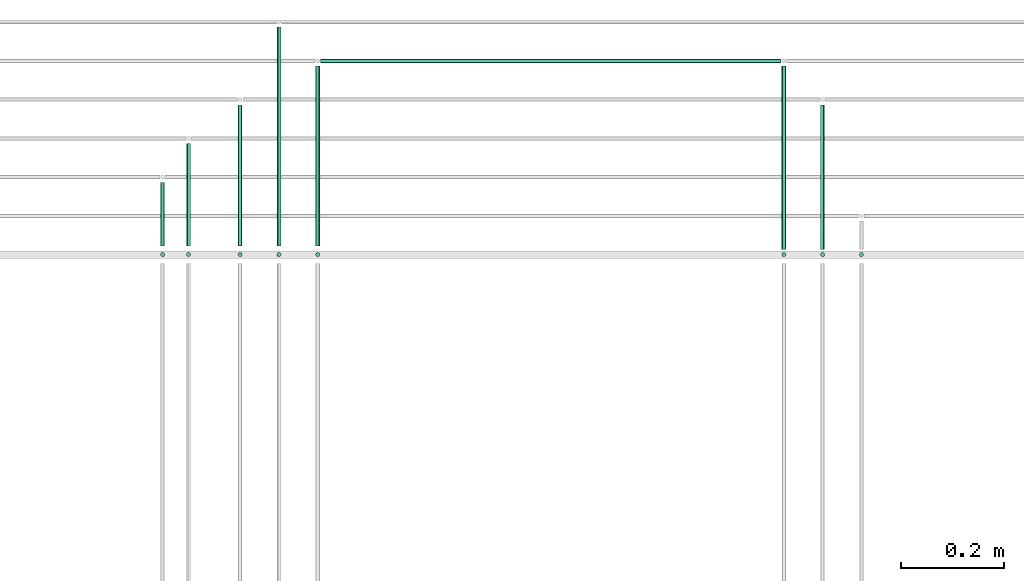
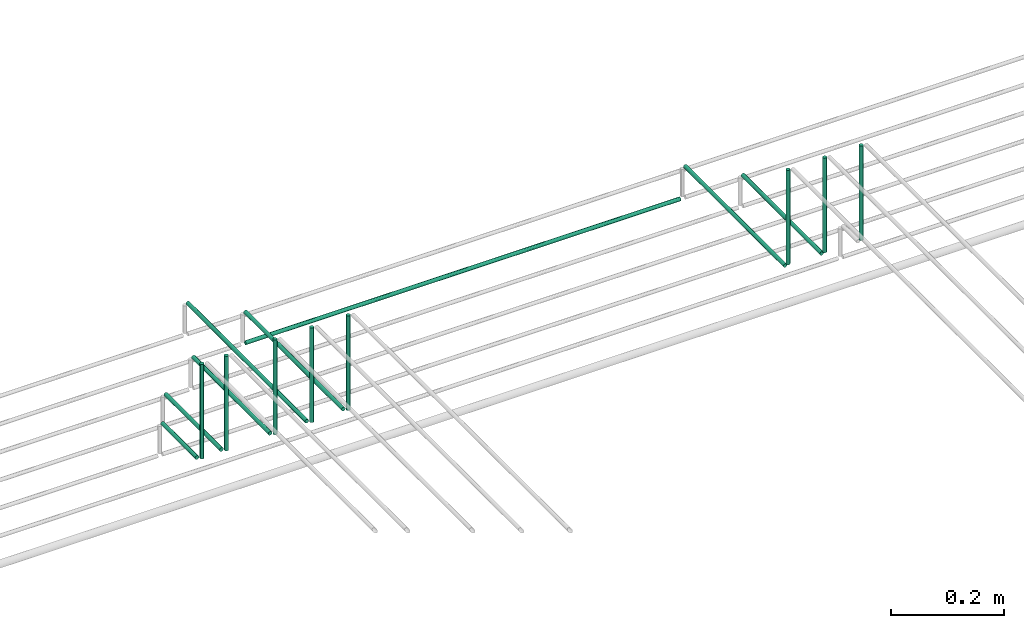
# One storey, part 64 of 89: 16 flow segments.
"""IFC2X3 building model written with IfcOpenShell, lengths in millimetres."""

import ifcopenshell
import ifcopenshell.guid

model = None  # the IFC model being written
_history = None  # IfcOwnerHistory: only IFC2X3 demands one
_inside = {}  # id of a spatial element -> (the spatial element, [elements in it])
_under = {}  # id of a project, library or spatial element -> (it, [spatial elements below it])
_declared = {}  # id of a project -> (the project, [libraries it declares])
_typed = {}  # id of a type object -> (the type object, [elements of that type])
_made_of = {}  # id of a material, layer set ... -> (it, [elements and type objects made of it])


def new_model(schema):
    """Start an empty IFC model of exactly this schema.

    Asked for "IFC4X3", IfcOpenShell would pick the latest addendum, in which some entities
    have other attributes; the version numbers below select the first issue.
    IFC2X3 requires an IfcOwnerHistory on every rooted entity: one is made here for all.
    """
    global model, _history
    if schema == "IFC4X3":
        model = ifcopenshell.file(schema_version=(4, 3, 0, 0))
    else:
        model = ifcopenshell.file(schema=schema)
    _inside.clear()
    _under.clear()
    _declared.clear()
    _typed.clear()
    _made_of.clear()
    _history = None
    if model.schema == "IFC2X3":
        org = make("IfcOrganization", Name="unknown")
        user = make(
            "IfcPersonAndOrganization",
            ThePerson=make("IfcPerson", FamilyName="unknown"),
            TheOrganization=org,
        )
        app = make(
            "IfcApplication",
            ApplicationDeveloper=org,
            Version="unknown",
            ApplicationFullName="unknown",
            ApplicationIdentifier="unknown",
        )
        _history = make(
            "IfcOwnerHistory",
            OwningUser=user,
            OwningApplication=app,
            ChangeAction="ADDED",
            CreationDate=0,
        )
    return model


def make(cls, **values):
    """One entity of the class cls with the attributes given. An attribute that is None is left unset."""
    return model.create_entity(
        cls, **{name: value for name, value in values.items() if value is not None}
    )


def entity(cls, *values):
    """Any entity or typed value of the class cls, its attributes in the order of the schema. None: left unset."""
    e = model.create_entity(cls)
    for i, value in enumerate(values):
        if value is not None:
            e[i] = value
    return e


def rooted(cls, **values):
    """An entity with a GlobalId (a new one), such as an element, a storey or a relation."""
    return make(cls, GlobalId=ifcopenshell.guid.new(), OwnerHistory=_history, **values)


def si_unit(unit_type, name, prefix=None):
    """IfcSIUnit, for example si_unit("LENGTHUNIT", "METRE", prefix="MILLI")."""
    return make("IfcSIUnit", UnitType=unit_type, Prefix=prefix, Name=name)


def converted_unit(unit_type, name, factor, base, dimensions=None, offset=None):
    """IfcConversionBasedUnit, such as the inch: factor (a typed value) times the base unit."""
    return make(
        "IfcConversionBasedUnit"
        if offset is None
        else "IfcConversionBasedUnitWithOffset",
        ConversionOffset=offset,
        Dimensions=None
        if dimensions is None
        else entity("IfcDimensionalExponents", *dimensions),
        UnitType=unit_type,
        Name=name,
        ConversionFactor=make(
            "IfcMeasureWithUnit", ValueComponent=factor, UnitComponent=base
        ),
    )


def derived_unit(unit_type, elements):
    """IfcDerivedUnit: a product of units, each with its exponent."""
    return make(
        "IfcDerivedUnit",
        Elements=[
            make("IfcDerivedUnitElement", Unit=unit, Exponent=power)
            for unit, power in elements
        ],
        UnitType=unit_type,
    )


def assignment(units):
    """IfcUnitAssignment: the units of a project."""
    return None if units is None else make("IfcUnitAssignment", Units=units)


def point(xyz):
    """IfcCartesianPoint."""
    return None if xyz is None else make("IfcCartesianPoint", Coordinates=xyz)


def direction(xyz):
    """IfcDirection."""
    return None if xyz is None else make("IfcDirection", DirectionRatios=xyz)


def frame(location, z_axis=None, x_axis=None):
    """IfcAxis2Placement3D, a coordinate frame: its origin and axes. An axis left out is left unset."""
    return make(
        "IfcAxis2Placement3D",
        Location=point(location),
        Axis=direction(z_axis),
        RefDirection=direction(x_axis),
    )


def frame_2d(location, x_axis=None):
    """IfcAxis2Placement2D, a coordinate frame in the plane: its origin and x axis."""
    return make(
        "IfcAxis2Placement2D", Location=point(location), RefDirection=direction(x_axis)
    )


def origin():
    """The frame at (0, 0, 0) with its axes left unset."""
    return frame((0.0, 0.0, 0.0))


def origin_2d_with_axis():
    """The frame at (0, 0) in the plane with the x axis (1, 0) written out."""
    return frame_2d((0.0, 0.0), x_axis=(1.0, 0.0))


def place(relative_to, where):
    """IfcLocalPlacement: puts the frame where relative to a parent placement (None: the world)."""
    return make(
        "IfcLocalPlacement", PlacementRelTo=relative_to, RelativePlacement=where
    )


def context(
    kind, dimensions, precision=None, world=None, true_north=None, identifier=None
):
    """IfcGeometricRepresentationContext, for example the 3D "Model" context."""
    return make(
        "IfcGeometricRepresentationContext",
        ContextIdentifier=identifier,
        ContextType=kind,
        CoordinateSpaceDimension=dimensions,
        Precision=precision,
        WorldCoordinateSystem=world,
        TrueNorth=true_north,
    )


def subcontext(parent, identifier, kind, view, scale=None):
    """IfcGeometricRepresentationSubContext, for example "Body" below "Model"."""
    return make(
        "IfcGeometricRepresentationSubContext",
        ContextIdentifier=identifier,
        ContextType=kind,
        ParentContext=parent,
        TargetScale=scale,
        TargetView=view,
    )


def project(units=None, contexts=None):
    """IfcProject with its units and contexts."""
    return rooted(
        "IfcProject",
        Name="project",
        RepresentationContexts=contexts,
        UnitsInContext=assignment(units),
    )


def spatial(cls, under=None, at=None, **own):
    """A site, building, storey or space (cls), placed at a placement, below another one or the project."""
    s = rooted(cls, ObjectPlacement=at, **own)
    if under is not None:
        _under.setdefault(under.id(), (under, []))[1].append(s)
    return s


def profile(cls, at=None, kind="AREA", **sizes):
    """A parametric profile (cls). Its sizes go by their IFC names, for example OverallWidth=200.0."""
    return make(cls, ProfileType=kind, Position=at, **sizes)


def circle(**sizes):
    """IfcCircleProfileDef."""
    return profile("IfcCircleProfileDef", **sizes)


def extrude(swept, where, along, depth):
    """IfcExtrudedAreaSolid: the profile swept, set in the frame where, extruded along a direction by depth."""
    return make(
        "IfcExtrudedAreaSolid",
        SweptArea=swept,
        Position=where,
        ExtrudedDirection=direction(along),
        Depth=depth,
    )


def shape(context_of_items, identifier, shape_type, items):
    """IfcShapeRepresentation: the items that make up one representation, for example the "Body"."""
    return make(
        "IfcShapeRepresentation",
        ContextOfItems=context_of_items,
        RepresentationIdentifier=identifier,
        RepresentationType=shape_type,
        Items=items,
    )


def made_of(thing, what):
    """Note that an element or type object is made of a material, layer set ...; save() writes the relation."""
    if what is not None:
        _made_of.setdefault(what.id(), (what, []))[1].append(thing)
    return thing


def type_object(cls, material=None, **own):
    """A type object (cls), such as IfcWallType, which elements share."""
    return made_of(rooted(cls, **own), material)


def element(
    cls,
    number,
    at=None,
    inside=None,
    cuts=None,
    type_object=None,
    material=None,
    context=None,
    identifier="Body",
    shape_type=None,
    held_by="IfcProductDefinitionShape",
    body=None,
    shapes=None,
    **own,
):
    """One element of the class cls, such as IfcWall. Its Tag is "e" and its number.

    at: its placement. inside: the storey or other place that contains it. cuts: it is an
    opening in that element (IfcRelVoidsElement). A single representation is given by context,
    identifier, shape_type and body (its items); several are given by shapes. held_by: the class
    of the entity that holds the representations. save() writes the other relations.
    """
    e = rooted(cls, Tag="e%d" % number, ObjectPlacement=at, **own)
    if body is not None:
        shapes = [shape(context, identifier, shape_type, body)]
    if shapes is not None:
        e.Representation = make(held_by, Representations=shapes)
    if inside is not None:
        _inside.setdefault(inside.id(), (inside, []))[1].append(e)
    if cuts is not None:
        rooted(
            "IfcRelVoidsElement", RelatingBuildingElement=cuts, RelatedOpeningElement=e
        )
    if type_object is not None:
        _typed.setdefault(type_object.id(), (type_object, []))[1].append(e)
    return made_of(e, material)


def aggregate(whole, parts):
    """IfcRelAggregates: a whole, such as a stair, and the parts it consists of."""
    return rooted("IfcRelAggregates", RelatingObject=whole, RelatedObjects=parts)


def save(model, path):
    """Write the relations noted so far, then the file.

    IfcRelAggregates (storeys below a building ...), IfcRelContainedInSpatialStructure (elements
    in a storey), IfcRelDefinesByType, IfcRelAssociatesMaterial and IfcRelDeclares: one each for
    every whole, place, type object, material and project.
    """
    for whole, parts in _under.values():
        aggregate(whole, parts)
    for where, things in _inside.values():
        rooted(
            "IfcRelContainedInSpatialStructure",
            RelatedElements=things,
            RelatingStructure=where,
        )
    for kind, things in _typed.values():
        rooted("IfcRelDefinesByType", RelatedObjects=things, RelatingType=kind)
    for what, things in _made_of.values():
        rooted("IfcRelAssociatesMaterial", RelatedObjects=things, RelatingMaterial=what)
    for by, libraries in _declared.values():
        rooted("IfcRelDeclares", RelatingContext=by, RelatedDefinitions=libraries)
    model.write(path)


model = new_model("IFC2X3")

# Units and contexts
model_context = context("Model", 3, precision=0.01, world=origin(), true_north=direction((6.12303176911189e-17, 1.0)))
body_context = subcontext(model_context, "Body", "Model", "MODEL_VIEW")
ifc_project = project(units=[si_unit("LENGTHUNIT", "METRE", prefix="MILLI"), si_unit("AREAUNIT", "SQUARE_METRE"), si_unit("VOLUMEUNIT", "CUBIC_METRE"), converted_unit("PLANEANGLEUNIT", "DEGREE", entity("IfcRatioMeasure", 0.0174532925199433), si_unit("PLANEANGLEUNIT", "RADIAN"), dimensions=[0, 0, 0, 0, 0, 0, 0]), si_unit("MASSUNIT", "GRAM", prefix="KILO"), derived_unit("MASSDENSITYUNIT", [(si_unit("MASSUNIT", "GRAM", prefix="KILO"), 1), (si_unit("LENGTHUNIT", "METRE"), -3)]), derived_unit("MOMENTOFINERTIAUNIT", [(si_unit("LENGTHUNIT", "METRE"), 4)]), si_unit("TIMEUNIT", "SECOND"), si_unit("FREQUENCYUNIT", "HERTZ"), si_unit("THERMODYNAMICTEMPERATUREUNIT", "DEGREE_CELSIUS"), derived_unit("THERMALTRANSMITTANCEUNIT", [(si_unit("MASSUNIT", "GRAM", prefix="KILO"), 1), (si_unit("THERMODYNAMICTEMPERATUREUNIT", "KELVIN"), -1), (si_unit("TIMEUNIT", "SECOND"), -3)]), derived_unit("VOLUMETRICFLOWRATEUNIT", [(si_unit("LENGTHUNIT", "METRE"), 3), (si_unit("TIMEUNIT", "SECOND"), -1)]), derived_unit("MASSFLOWRATEUNIT", [(si_unit("MASSUNIT", "GRAM", prefix="KILO"), 1), (si_unit("TIMEUNIT", "SECOND"), -1)]), derived_unit("ROTATIONALFREQUENCYUNIT", [(si_unit("TIMEUNIT", "SECOND"), -1)]), si_unit("ELECTRICCURRENTUNIT", "AMPERE"), si_unit("ELECTRICVOLTAGEUNIT", "VOLT"), si_unit("POWERUNIT", "WATT"), si_unit("FORCEUNIT", "NEWTON", prefix="KILO"), si_unit("ILLUMINANCEUNIT", "LUX"), si_unit("LUMINOUSFLUXUNIT", "LUMEN"), si_unit("LUMINOUSINTENSITYUNIT", "CANDELA"), derived_unit("USERDEFINED", [(si_unit("MASSUNIT", "GRAM", prefix="KILO"), -1), (si_unit("LENGTHUNIT", "METRE"), -2), (si_unit("TIMEUNIT", "SECOND"), 3), (si_unit("LUMINOUSFLUXUNIT", "LUMEN"), 1)]), derived_unit("LINEARVELOCITYUNIT", [(si_unit("LENGTHUNIT", "METRE"), 1), (si_unit("TIMEUNIT", "SECOND"), -1)]), si_unit("PRESSUREUNIT", "PASCAL"), derived_unit("USERDEFINED", [(si_unit("LENGTHUNIT", "METRE"), -2), (si_unit("MASSUNIT", "GRAM", prefix="KILO"), 1), (si_unit("TIMEUNIT", "SECOND"), -2)]), derived_unit("LINEARFORCEUNIT", [(si_unit("MASSUNIT", "GRAM", prefix="KILO"), 1), (si_unit("LENGTHUNIT", "METRE"), 1), (si_unit("TIMEUNIT", "SECOND"), -2), (si_unit("LENGTHUNIT", "METRE"), -1)]), derived_unit("PLANARFORCEUNIT", [(si_unit("MASSUNIT", "GRAM", prefix="KILO"), 1), (si_unit("LENGTHUNIT", "METRE"), 1), (si_unit("TIMEUNIT", "SECOND"), -2), (si_unit("LENGTHUNIT", "METRE"), -2)])], contexts=[model_context])

# Site, building, storey
site_placement = place(None, frame((0.0, -0.00077364408347762, 0.0)))
site = spatial("IfcSite", under=ifc_project, at=site_placement, CompositionType="ELEMENT")
building_placement = place(site_placement, origin())
building = spatial("IfcBuilding", under=site, at=building_placement, CompositionType="ELEMENT")
storey_placement = place(building_placement, frame((0.0, 0.0, 24000.0)))
storey = spatial("IfcBuildingStorey", under=building, at=storey_placement, CompositionType="ELEMENT", Elevation=24000.0)

# Flow segments
pipe_segment_type = type_object("IfcPipeSegmentType", PredefinedType="NOTDEFINED")
flow_segment_1_placement = place(storey_placement, frame((58948.2213692066, 18644.5582806598, 2859.99965095085)))
element("IfcFlowSegment", 1, at=flow_segment_1_placement, inside=storey, type_object=pipe_segment_type, context=body_context, shape_type="SweptSolid", body=[
    extrude(circle(Radius=4.0, at=origin_2d_with_axis()), frame((5.5952722206509, 5.59527223591499, 0.000349592837017099), z_axis=(8.73982106718787e-05, 0.0, 0.999999996180776), x_axis=(0.999999996180776, 0.0, -8.73982106718787e-05)), (0.0, 0.0, 1.0), 205.000000850331),
])
flow_segment_2_placement = place(storey_placement, frame((58948.2218546044, 18667.1535528393, 2844.40472924287)))
element("IfcFlowSegment", 2, at=flow_segment_2_placement, inside=storey, type_object=pipe_segment_type, context=body_context, shape_type="SweptSolid", body=[
    extrude(circle(Radius=4.0, at=origin_2d_with_axis()), frame((5.59527223591499, 0.0, 5.59527223591499), z_axis=(0.0, 1.0, 0.0), x_axis=(-1.0, 0.0, 0.0)), (0.0, 0.0, 1.0), 122.846447160764),
])
flow_segment_3_placement = place(storey_placement, frame((58998.2213692066, 18644.5582806598, 2859.99965095085)))
element("IfcFlowSegment", 3, at=flow_segment_3_placement, inside=storey, type_object=pipe_segment_type, context=body_context, shape_type="SweptSolid", body=[
    extrude(circle(Radius=4.0, at=origin_2d_with_axis()), frame((5.59527222064223, 5.59527223591499, 0.000349592837017099), z_axis=(8.73982106718787e-05, 0.0, 0.999999996180776), x_axis=(0.999999996180776, 0.0, -8.73982106718787e-05)), (0.0, 0.0, 1.0), 205.000000850331),
])
for number, where in (
    (4, (59098.2213692066, 18644.5582806598, 2859.99965095085)),
    (5, (59173.2213692066, 18644.5582806598, 2859.99965095085)),
    (6, (59248.2213692066, 18644.5582806598, 2859.99965095085)),
):
    element("IfcFlowSegment", number, at=place(storey_placement, frame(where)), inside=storey, type_object=pipe_segment_type, context=body_context, shape_type="SweptSolid", body=[
        extrude(circle(Radius=4.0, at=origin_2d_with_axis()), frame((5.5952722206509, 5.59527223591499, 0.000349592837017099), z_axis=(8.73982106718787e-05, 0.0, 0.999999996180776), x_axis=(0.999999996180776, 0.0, -8.73982106718787e-05)), (0.0, 0.0, 1.0), 205.000000850331),
    ])
flow_segment_4_placement = place(storey_placement, frame((58998.2218546044, 18667.1535528393, 2844.40472986988)))
element("IfcFlowSegment", 7, at=flow_segment_4_placement, inside=storey, type_object=pipe_segment_type, context=body_context, shape_type="SweptSolid", body=[
    extrude(circle(Radius=4.0, at=origin_2d_with_axis()), frame((5.59527223591499, 0.0, 5.59527223591499), z_axis=(0.0, 1.0, 0.0), x_axis=(-1.0, 0.0, 0.0)), (0.0, 0.0, 1.0), 197.846447160764),
])
flow_segment_5_placement = place(storey_placement, frame((59098.2218546044, 18667.1535528393, 2844.40473042311)))
element("IfcFlowSegment", 8, at=flow_segment_5_placement, inside=storey, type_object=pipe_segment_type, context=body_context, shape_type="SweptSolid", body=[
    extrude(circle(Radius=4.0, at=origin_2d_with_axis()), frame((5.59527223591499, 0.0, 5.59527223591499), z_axis=(0.0, 1.0, 0.0), x_axis=(-1.0, 0.0, 0.0)), (0.0, 0.0, 1.0), 272.84644716076),
])
flow_segment_6_placement = place(storey_placement, frame((59173.2218546044, 18667.1535528393, 2844.40473152958)))
element("IfcFlowSegment", 9, at=flow_segment_6_placement, inside=storey, type_object=pipe_segment_type, context=body_context, shape_type="SweptSolid", body=[
    extrude(circle(Radius=4.0, at=origin_2d_with_axis()), frame((5.59527223591499, 0.0, 5.59527223591499), z_axis=(0.0, 1.0, 0.0), x_axis=(-1.0, 0.0, 0.0)), (0.0, 0.0, 1.0), 422.846447160774),
])
flow_segment_7_placement = place(storey_placement, frame((59248.2218546044, 18667.1535528393, 2844.40473097634)))
element("IfcFlowSegment", 10, at=flow_segment_7_placement, inside=storey, type_object=pipe_segment_type, context=body_context, shape_type="SweptSolid", body=[
    extrude(circle(Radius=4.0, at=origin_2d_with_axis()), frame((5.59527223591499, 0.0, 5.59527223591499), z_axis=(0.0, 1.0, 0.0), x_axis=(-1.0, 0.0, 0.0)), (0.0, 0.0, 1.0), 347.846447160776),
])
flow_segment_8_placement = place(storey_placement, frame((60225.057491191, 18644.5582806598, 2859.99965095085)))
element("IfcFlowSegment", 11, at=flow_segment_8_placement, inside=storey, type_object=pipe_segment_type, context=body_context, shape_type="SweptSolid", body=[
    extrude(circle(Radius=4.0, at=origin_2d_with_axis()), frame((5.5952722206509, 5.59527223591499, 0.000349592837017099), z_axis=(8.73982106718787e-05, 0.0, 0.999999996180776), x_axis=(0.999999996180776, 0.0, -8.73982106718787e-05)), (0.0, 0.0, 1.0), 205.000000850331),
])
flow_segment_9_placement = place(storey_placement, frame((60225.022318224, 18660.0, 2844.40473038549)))
element("IfcFlowSegment", 12, at=flow_segment_9_placement, inside=storey, type_object=pipe_segment_type, context=body_context, shape_type="SweptSolid", body=[
    extrude(circle(Radius=4.0, at=origin_2d_with_axis()), frame((5.59527223591499, 0.0, 5.59527223591499), z_axis=(0.0, 1.0, 0.0), x_axis=(-1.0, 0.0, 0.0)), (0.0, 0.0, 1.0), 280.000000001725),
])
flow_segment_10_placement = place(storey_placement, frame((60150.057491191, 18644.5582806598, 2859.99965095085)))
element("IfcFlowSegment", 13, at=flow_segment_10_placement, inside=storey, type_object=pipe_segment_type, context=body_context, shape_type="SweptSolid", body=[
    extrude(circle(Radius=4.0, at=origin_2d_with_axis()), frame((5.5952722206509, 5.59527223591499, 0.000349592837017099), z_axis=(8.73982106718787e-05, 0.0, 0.999999996180776), x_axis=(0.999999996180776, 0.0, -8.73982106718787e-05)), (0.0, 0.0, 1.0), 205.000000850331),
])
flow_segment_11_placement = place(storey_placement, frame((60150.022318224, 18660.0, 2844.40473089656)))
element("IfcFlowSegment", 14, at=flow_segment_11_placement, inside=storey, type_object=pipe_segment_type, context=body_context, shape_type="SweptSolid", body=[
    extrude(circle(Radius=4.0, at=origin_2d_with_axis()), frame((5.59527223591499, 0.0, 5.59527223591499), z_axis=(0.0, 1.0, 0.0), x_axis=(-1.0, 0.0, 0.0)), (0.0, 0.0, 1.0), 355.000000001739),
])
flow_segment_12_placement = place(storey_placement, frame((60300.057491191, 18644.5582806598, 2859.99965095085)))
element("IfcFlowSegment", 15, at=flow_segment_12_placement, inside=storey, type_object=pipe_segment_type, context=body_context, shape_type="SweptSolid", body=[
    extrude(circle(Radius=4.0, at=origin_2d_with_axis()), frame((5.5952722206509, 5.59527223591499, 0.000349592837017099), z_axis=(8.73982106718787e-05, 0.0, 0.999999996180776), x_axis=(0.999999996180776, 0.0, -8.73982106718787e-05)), (0.0, 0.0, 1.0), 205.000000850331),
])
flow_segment_13_placement = place(storey_placement, frame((59258.8171268404, 19019.4047277642, 2769.4047277641)))
element("IfcFlowSegment", 16, at=flow_segment_13_placement, inside=storey, type_object=pipe_segment_type, context=body_context, shape_type="SweptSolid", body=[
    extrude(circle(Radius=4.0, at=origin_2d_with_axis()), frame((0.0, 5.59527223591499, 5.59527223591499), z_axis=(1.0, 0.0, 0.0), x_axis=(0.0, -1.0, 0.0)), (0.0, 0.0, 1.0), 891.80046361957),
])

save(model, "model.ifc")
